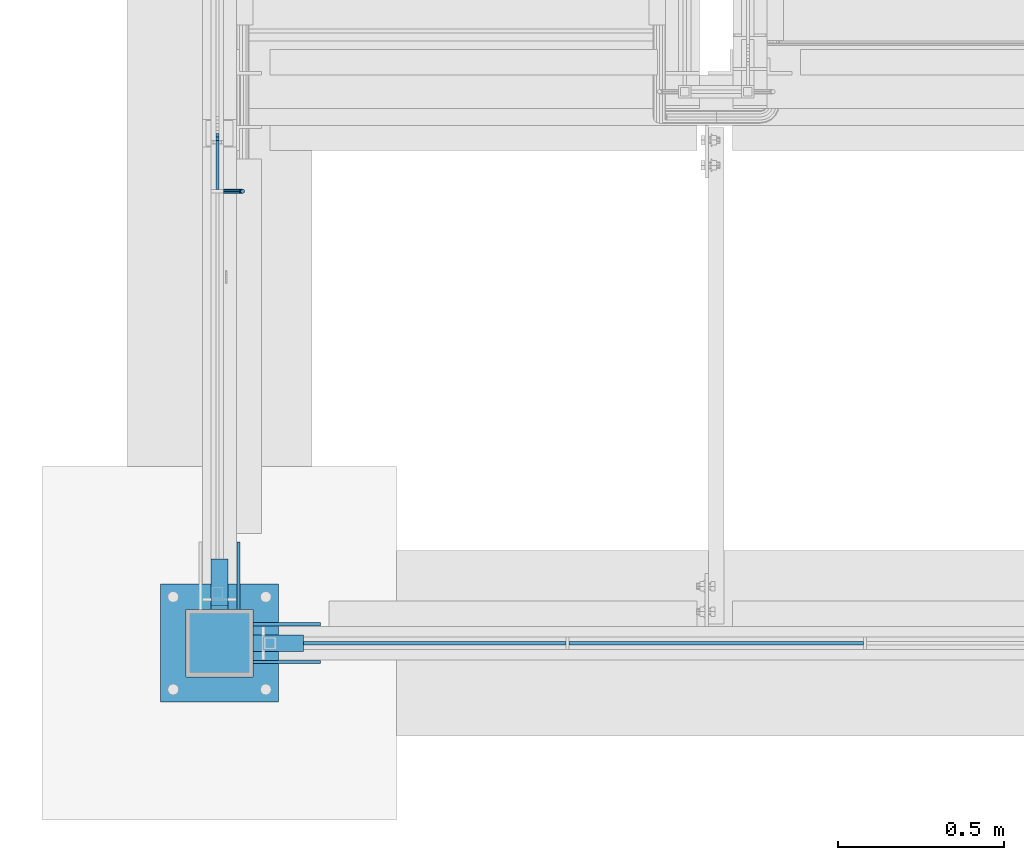
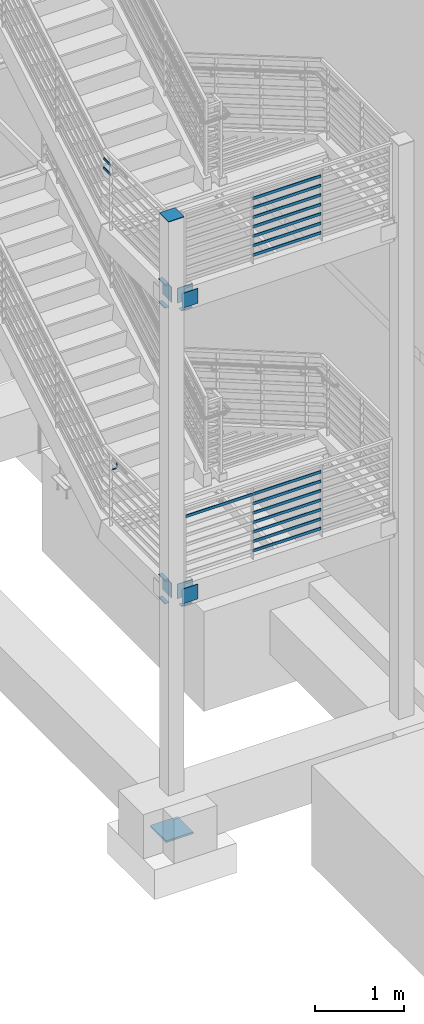
# One storey, part 831 of 1179: 32 beams, 7 elements without a shape of their own.
"""IFC2X3 building model written with IfcOpenShell, lengths in millimetres."""

from ifc_helpers import new_model, si_unit, frame, origin_with_axes, place, context, subcontext, project, spatial, faceted_brep, material, type_object, element, aggregate, save


model = new_model("IFC2X3")

# Units and contexts
model_context = context("Model", 3, precision=1e-05, world=origin_with_axes())
body_context = subcontext(model_context, "Body", "Model", "MODEL_VIEW")
ifc_project = project(units=[si_unit("LENGTHUNIT", "METRE", prefix="MILLI"), si_unit("AREAUNIT", "SQUARE_METRE"), si_unit("VOLUMEUNIT", "CUBIC_METRE"), si_unit("MASSUNIT", "GRAM", prefix="KILO"), si_unit("TIMEUNIT", "SECOND"), si_unit("PLANEANGLEUNIT", "RADIAN"), si_unit("SOLIDANGLEUNIT", "STERADIAN"), si_unit("THERMODYNAMICTEMPERATUREUNIT", "DEGREE_CELSIUS"), si_unit("LUMINOUSINTENSITYUNIT", "LUMEN")], contexts=[model_context])

# Site, building, storey
site_placement = place(None, origin_with_axes())
site = spatial("IfcSite", under=ifc_project, at=site_placement, CompositionType="ELEMENT")
building_placement = place(site_placement, origin_with_axes())
building = spatial("IfcBuilding", under=site, at=building_placement, Name="Undefined", CompositionType="ELEMENT")
storey_placement = place(building_placement, origin_with_axes())
storey = spatial("IfcBuildingStorey", under=building, at=storey_placement, Name="Undefined", CompositionType="ELEMENT", Elevation=0.0)

# Assembly, beam
assembly_1_placement = place(storey_placement, origin_with_axes())
assembly_1 = element("IfcElementAssembly", 1, at=assembly_1_placement, inside=storey, Name="COLUMN", AssemblyPlace="NOTDEFINED", PredefinedType="RIGID_FRAME")
ifc_material_1 = material(Name="STEEL/A572-GR.50")
beam_type_1 = type_object("IfcBeamType", PredefinedType="NOTDEFINED")
beam_1_placement = place(assembly_1_placement, frame((-3251.2, 30327.6, 1857.375), z_axis=(1.0, 0.0, 0.0), x_axis=(0.0, -1.0, 0.0)))
beam_1 = element("IfcBeam", 2, at=beam_1_placement, type_object=beam_type_1, material=ifc_material_1, Name="PLATE", context=body_context, shape_type="Brep", body=[
    faceted_brep([(152.400000000001, -6.35000000000036, 25.4), (152.400000000001, -6.35000000000036, -25.4), (139.700000000004, 6.35000000000036, -25.4), (139.700000000004, 6.35000000000036, 25.4), (0.0, -6.35000000000036, -25.4000000000015), (0.0, -6.35000000000036, 25.4000000000015), (0.0, 6.35000000000036, 25.4000000000015), (0.0, 6.35000000000036, -25.4000000000015)], [[[0, 1, 2, 3]], [[4, 5, 6, 7]], [[6, 5, 0, 3]], [[7, 6, 3, 2]], [[4, 7, 2, 1]], [[5, 4, 1, 0]]]),
])

assembly_2_placement = place(storey_placement, origin_with_axes())
assembly_2 = element("IfcElementAssembly", 3, at=assembly_2_placement, inside=storey, Name="PLATE", AssemblyPlace="NOTDEFINED", PredefinedType="RIGID_FRAME")
beam_2_placement = place(assembly_2_placement, frame((-3251.2, 30327.6, 2174.875), z_axis=(1.0, 0.0, 0.0), x_axis=(0.0, -1.0, 0.0)))
beam_2 = element("IfcBeam", 4, at=beam_2_placement, type_object=beam_type_1, material=ifc_material_1, Name="PLATE", context=body_context, shape_type="Brep", body=[
    faceted_brep([(152.399999999998, 6.35000000000036, 25.4000000000015), (139.699999999998, -6.35000000000036, 25.4000000000015), (139.699999999998, -6.35000000000036, -25.4000000000015), (152.399999999998, 6.35000000000036, -25.4000000000015), (0.0, -6.35000000000036, -25.4000000000015), (0.0, -6.35000000000036, 25.4000000000015), (0.0, 6.35000000000036, 25.4000000000015), (0.0, 6.35000000000036, -25.4000000000015)], [[[0, 1, 2, 3]], [[4, 5, 6, 7]], [[7, 6, 0, 3]], [[4, 7, 3, 2]], [[5, 4, 2, 1]], [[6, 5, 1, 0]]]),
])
aggregate(assembly_2, [beam_2])

# Beam
beam_3_placement = place(assembly_1_placement, frame((-3251.2, 30327.6, 5930.9), z_axis=(1.0, 0.0, 0.0), x_axis=(0.0, -1.0, 0.0)))
beam_3 = element("IfcBeam", 5, at=beam_3_placement, type_object=beam_type_1, material=ifc_material_1, Name="PLATE", context=body_context, shape_type="Brep", body=[
    faceted_brep([(152.400000000001, -6.35000000000036, 25.4), (152.400000000001, -6.35000000000036, -25.4), (139.700000000004, 6.35000000000036, -25.4), (139.700000000004, 6.35000000000036, 25.4), (0.0, -6.35000000000036, -25.4000000000015), (0.0, -6.35000000000036, 25.4000000000015), (0.0, 6.35000000000036, 25.4000000000015), (0.0, 6.35000000000036, -25.4000000000015)], [[[0, 1, 2, 3]], [[4, 5, 6, 7]], [[6, 5, 0, 3]], [[7, 6, 3, 2]], [[4, 7, 2, 1]], [[5, 4, 1, 0]]]),
])

# Assembly, beam
assembly_3_placement = place(storey_placement, origin_with_axes())
assembly_3 = element("IfcElementAssembly", 6, at=assembly_3_placement, inside=storey, Name="PLATE", AssemblyPlace="NOTDEFINED", PredefinedType="RIGID_FRAME")
beam_4_placement = place(assembly_3_placement, frame((-3251.2, 30327.6, 6248.4), z_axis=(1.0, 0.0, 0.0), x_axis=(0.0, -1.0, 0.0)))
beam_4 = element("IfcBeam", 7, at=beam_4_placement, type_object=beam_type_1, material=ifc_material_1, Name="PLATE", context=body_context, shape_type="Brep", body=[
    faceted_brep([(152.399999999998, 6.35000000000036, 25.4000000000015), (139.699999999998, -6.35000000000036, 25.4000000000015), (139.699999999998, -6.35000000000036, -25.4000000000015), (152.399999999998, 6.35000000000036, -25.4000000000015), (0.0, -6.35000000000036, -25.4000000000015), (0.0, -6.35000000000036, 25.4000000000015), (0.0, 6.35000000000036, 25.4000000000015), (0.0, 6.35000000000036, -25.4000000000015)], [[[0, 1, 2, 3]], [[4, 5, 6, 7]], [[7, 6, 0, 3]], [[4, 7, 3, 2]], [[5, 4, 2, 1]], [[6, 5, 1, 0]]]),
])
aggregate(assembly_3, [beam_4])

# Beam
beam_5_placement = place(assembly_1_placement, frame((-2997.2, 30073.6, 1857.375), z_axis=(0.0, 1.0, 0.0), x_axis=(-1.0, 0.0, 0.0)))
beam_5 = element("IfcBeam", 8, at=beam_5_placement, type_object=beam_type_1, material=ifc_material_1, Name="PLATE", context=body_context, shape_type="Brep", body=[
    faceted_brep([(152.399999999998, 6.35000000000036, 25.4000000000015), (139.699999999998, -6.35000000000036, 25.4000000000015), (139.699999999998, -6.35000000000036, -25.4000000000015), (152.399999999998, 6.35000000000036, -25.4000000000015), (0.0, -6.35000000000036, -25.4000000000015), (0.0, -6.35000000000036, 25.4000000000015), (0.0, 6.35000000000036, 25.4000000000015), (0.0, 6.35000000000036, -25.4000000000015)], [[[0, 1, 2, 3]], [[4, 5, 6, 7]], [[7, 6, 0, 3]], [[4, 7, 3, 2]], [[5, 4, 2, 1]], [[6, 5, 1, 0]]]),
])

beam_6_placement = place(assembly_1_placement, frame((-2997.2, 30073.6, 5930.9), z_axis=(0.0, 1.0, 0.0), x_axis=(-1.0, 0.0, 0.0)))
beam_6 = element("IfcBeam", 9, at=beam_6_placement, type_object=beam_type_1, material=ifc_material_1, Name="PLATE", context=body_context, shape_type="Brep", body=[
    faceted_brep([(152.399999999998, 6.35000000000036, 25.4000000000015), (139.699999999998, -6.35000000000036, 25.4000000000015), (139.699999999998, -6.35000000000036, -25.4000000000015), (152.399999999998, 6.35000000000036, -25.4000000000015), (0.0, -6.35000000000036, -25.4000000000015), (0.0, -6.35000000000036, 25.4000000000015), (0.0, 6.35000000000036, 25.4000000000015), (0.0, 6.35000000000036, -25.4000000000015)], [[[0, 1, 2, 3]], [[4, 5, 6, 7]], [[7, 6, 0, 3]], [[4, 7, 3, 2]], [[5, 4, 2, 1]], [[6, 5, 1, 0]]]),
])

# Assembly, beam
assembly_4_placement = place(storey_placement, origin_with_axes())
assembly_4 = element("IfcElementAssembly", 10, at=assembly_4_placement, inside=storey, Name="GUARDRAIL", AssemblyPlace="NOTDEFINED", PredefinedType="RIGID_FRAME")
ifc_material_2 = material(Name="STEEL/A36")
beam_type_2 = type_object("IfcBeamType", PredefinedType="NOTDEFINED")
beam_7_placement = place(assembly_4_placement, frame((-3238.5000060417, 31436.7333332685, 2936.87500000931), z_axis=(0.0, 0.0, 1.0), x_axis=(1.0, 0.0, 0.0)))
beam_7 = element("IfcBeam", 11, at=beam_7_placement, type_object=beam_type_2, material=ifc_material_2, Name="BRACKET", context=body_context, shape_type="Brep", body=[
    faceted_brep([(0.0, -4.49012806053361, 4.49012806053452), (0.0, 0.0, 6.34999999999991), (0.0, 4.49012806053361, 4.49012806053452), (0.0, 6.34999999999854, 0.0), (0.0, 4.49012806053361, -4.49012806053452), (0.0, 0.0, -6.34999999999991), (0.0, -4.49012806053361, -4.49012806053452), (0.0, -6.34999999999854, 0.0), (44.4500031699827, 0.0, -6.34999999999991), (44.4500031699827, -4.49012806053361, -4.49012806053452), (44.4500031699827, -6.34999999999854, 2.19733919948339e-09), (44.4500031699827, -4.49012806053361, 4.49012806053452), (44.4500031699827, 0.0, 6.34999999999991), (44.4500031699827, 4.49012806053361, 4.49012806053452), (44.4500031699827, 6.34999999999854, 0.0), (44.4500031699827, 4.49012806053361, -4.49012806053452), (53.0450671075391, 4.4901280570557, -2.18708762112465), (53.97500307462, -4.32919478043914e-09, -3.79778396764459), (53.0450671022344, -4.49012806401151, -2.1870876194389), (50.8000030708674, -6.35000000142099, 1.70147734757802), (48.5549390416977, -4.4901280599006, 5.59004231389645), (47.6250030746168, 1.48793333210051e-09, 7.20073866041594), (48.5549390470023, 4.49012806117025, 5.5900423122107), (50.8000030783693, 6.34999999857973, 1.70147734519378), (55.4485256393576, 6.34999999469437, 6.34999990618098), (59.337090604122, 4.49012805180246, 4.10493587545716), (51.5599606707875, 4.49012805866005, 8.59506393599531), (49.9492643188311, -4.54747350886464e-10, 9.52499990463002), (51.5599606615996, -4.4901280624108, 8.59506393379797), (55.4485256263639, -6.35000000530636, 6.34999990307369), (59.337090594938, -4.49012806926839, 4.10493587326664), (60.9477869468905, -1.0153598850593e-08, 3.17499990462466), (61.6401310450869, 4.49012804462109, 12.6999998130159), (63.5000029792477, -1.81098585017025e-08, 12.6999998092651), (57.1500029867496, 6.3499999893902, 12.6999998145698), (52.6598749240178, 4.49012805522943, 12.6999998130159), (50.8000029792477, -3.10683390125632e-09, 12.6999998092651), (52.6598749134085, -4.49012806583778, 12.6999998055144), (57.1500029739432, -6.35000001061053, 12.6999998039605), (61.6401310344776, -4.49012807644976, 12.6999998055144), (63.5000029792478, -6.94672053214163e-08, 76.1999999999989), (61.6401310356729, -4.49012812829824, 76.1999999999989), (57.1500029739432, -6.3500000636559, 76.1999999999989), (52.6598749146037, -4.49012812008004, 76.1999999999989), (50.8000029792478, -5.78438630327582e-08, 76.1999999999989), (52.6598749228227, 4.49012800098717, 76.1999999999989), (57.1500029850595, 6.34999993634483, 76.1999999999989), (61.6401310438919, 4.49012799276898, 76.1999999999989)], [[[0, 1, 2, 3, 4, 5, 6, 7]], [[6, 5, 8, 9]], [[7, 6, 9, 10]], [[0, 7, 10, 11]], [[1, 0, 11, 12]], [[2, 1, 12, 13]], [[3, 2, 13, 14]], [[4, 3, 14, 15]], [[5, 4, 15, 8]], [[8, 15, 16, 17]], [[9, 8, 17, 18]], [[10, 9, 18, 19]], [[11, 10, 19, 20]], [[12, 11, 20, 21]], [[13, 12, 21, 22]], [[14, 13, 22, 23]], [[15, 14, 23, 16]], [[23, 24, 25, 16]], [[22, 26, 24, 23]], [[21, 27, 26, 22]], [[20, 28, 27, 21]], [[19, 29, 28, 20]], [[18, 30, 29, 19]], [[17, 31, 30, 18]], [[16, 25, 31, 17]], [[25, 32, 33, 31]], [[24, 34, 32, 25]], [[26, 35, 34, 24]], [[27, 36, 35, 26]], [[28, 37, 36, 27]], [[29, 38, 37, 28]], [[30, 39, 38, 29]], [[31, 33, 39, 30]], [[39, 33, 40, 41]], [[38, 39, 41, 42]], [[37, 38, 42, 43]], [[36, 37, 43, 44]], [[35, 36, 44, 45]], [[34, 35, 45, 46]], [[32, 34, 46, 47]], [[33, 32, 47, 40]], [[46, 45, 44, 43, 42, 41, 40, 47]]]),
])
aggregate(assembly_4, [beam_7])

# Assembly, beams
assembly_5_placement = place(storey_placement, origin_with_axes())
assembly_5 = element("IfcElementAssembly", 12, at=assembly_5_placement, inside=storey, Name="GUARDRAIL", AssemblyPlace="NOTDEFINED", PredefinedType="RIGID_FRAME")
beam_type_3 = type_object("IfcBeamType", PredefinedType="NOTDEFINED")
beam_8_placement = place(assembly_5_placement, frame((-3257.54999923555, 31616.944156247, 7131.09462608346), z_axis=(0.0, 0.0, 1.0), x_axis=(0.0, -1.0, 0.0)))
beam_8 = element("IfcBeam", 13, at=beam_8_placement, type_object=beam_type_3, material=ifc_material_2, Name="PLATE", context=body_context, shape_type="Brep", body=[
    faceted_brep([(16.5954980612551, 4.76249999999982, -19.0500000000002), (26.8953347134957, 4.76249999999982, 19.0500000000002), (175.448322913624, 4.76249999999982, 19.0500000000002), (175.448322913624, 4.76249999999982, -19.0500000000002), (26.8953347134957, -4.76249999999982, 19.0500000000002), (175.448322913624, -4.76249999999982, 19.0500000000002), (16.5954980612551, -4.76249999999982, -19.0500000000002), (175.448322913624, -4.76249999999982, -19.0500000000002)], [[[0, 1, 2, 3]], [[1, 4, 5, 2]], [[4, 6, 7, 5]], [[6, 0, 3, 7]], [[5, 7, 3, 2]], [[6, 4, 1, 0]]]),
])
beam_9_placement = place(assembly_5_placement, frame((-3257.54999923555, 31616.944156247, 7000.90607249299), z_axis=(0.0, 0.0, 1.0), x_axis=(0.0, -1.0, 0.0)))
beam_9 = element("IfcBeam", 14, at=beam_9_placement, type_object=beam_type_3, material=ifc_material_2, Name="PLATE", context=body_context, shape_type="Brep", body=[
    faceted_brep([(6.3188973583201, 4.76249999999982, -19.0500000000002), (16.6187340105607, 4.76249999999982, 19.0500000000002), (175.448322913624, 4.76249999999982, 19.0500000000002), (175.448322913624, 4.76249999999982, -19.0500000000002), (16.6187340105607, -4.76249999999982, 19.0500000000002), (175.448322913624, -4.76249999999982, 19.0500000000002), (6.3188973583201, -4.76249999999982, -19.0500000000002), (175.448322913624, -4.76249999999982, -19.0500000000002)], [[[0, 1, 2, 3]], [[1, 4, 5, 2]], [[4, 6, 7, 5]], [[6, 0, 3, 7]], [[5, 7, 3, 2]], [[6, 4, 1, 0]]]),
])
aggregate(assembly_5, [beam_8, beam_9])

assembly_6_placement = place(storey_placement, origin_with_axes())
assembly_6 = element("IfcElementAssembly", 15, at=assembly_6_placement, inside=storey, Name="GUARDRAIL", AssemblyPlace="NOTDEFINED", PredefinedType="RIGID_FRAME")
beam_10_placement = place(assembly_6_placement, frame((-2201.33333333333, 30073.6, 6350.05291805541), z_axis=(0.0, 0.0, 1.0), x_axis=(1.0, 0.0, 0.0)))
beam_10 = element("IfcBeam", 16, at=beam_10_placement, type_object=beam_type_3, material=ifc_material_2, Name="PLATE", context=body_context, shape_type="Brep", body=[
    faceted_brep([(4.76250000197615, 4.76249999999999, -19.0500000000002), (4.76250000197615, 4.76249999999999, 19.0500000000002), (892.704166666667, 4.76249999999709, 19.0499999999993), (892.704166666667, 4.76249999999709, -19.0499999999993), (4.76250000197615, -4.76249999999999, 19.0500000000002), (892.704166666667, -4.76249999999709, 19.0499999999993), (4.76250000197615, -4.76249999999999, -19.0500000000002), (892.704166666667, -4.76249999999709, -19.0499999999993)], [[[0, 1, 2, 3]], [[1, 4, 5, 2]], [[4, 6, 7, 5]], [[6, 0, 3, 7]], [[5, 7, 3, 2]], [[6, 4, 1, 0]]]),
])
beam_11_placement = place(assembly_6_placement, frame((-2201.33333333333, 30073.6, 6480.22791850857), z_axis=(0.0, 0.0, 1.0), x_axis=(1.0, 0.0, 0.0)))
beam_11 = element("IfcBeam", 17, at=beam_11_placement, type_object=beam_type_3, material=ifc_material_2, Name="PLATE", context=body_context, shape_type="Brep", body=[
    faceted_brep([(4.76250000197615, 4.76249999999999, -19.0500000000002), (4.76250000197615, 4.76249999999999, 19.0500000000002), (892.704166666667, 4.76249999999709, 19.0499999999993), (892.704166666667, 4.76249999999709, -19.0499999999993), (4.76250000197615, -4.76249999999999, 19.0500000000002), (892.704166666667, -4.76249999999709, 19.0499999999993), (4.76250000197615, -4.76249999999999, -19.0500000000002), (892.704166666667, -4.76249999999709, -19.0499999999993)], [[[0, 1, 2, 3]], [[1, 4, 5, 2]], [[4, 6, 7, 5]], [[6, 0, 3, 7]], [[5, 7, 3, 2]], [[6, 4, 1, 0]]]),
])
beam_12_placement = place(assembly_6_placement, frame((-2201.33333333333, 30073.6, 6610.40291806788), z_axis=(0.0, 0.0, 1.0), x_axis=(1.0, 0.0, 0.0)))
beam_12 = element("IfcBeam", 18, at=beam_12_placement, type_object=beam_type_3, material=ifc_material_2, Name="PLATE", context=body_context, shape_type="Brep", body=[
    faceted_brep([(4.76250000197615, 4.76249999999999, -19.0500000000002), (4.76250000197615, 4.76249999999999, 19.0500000000002), (892.704166666667, 4.76249999999709, 19.0499999999993), (892.704166666667, 4.76249999999709, -19.0499999999993), (4.76250000197615, -4.76249999999999, 19.0500000000002), (892.704166666667, -4.76249999999709, 19.0499999999993), (4.76250000197615, -4.76249999999999, -19.0500000000002), (892.704166666667, -4.76249999999709, -19.0499999999993)], [[[0, 1, 2, 3]], [[1, 4, 5, 2]], [[4, 6, 7, 5]], [[6, 0, 3, 7]], [[5, 7, 3, 2]], [[6, 4, 1, 0]]]),
])
beam_13_placement = place(assembly_6_placement, frame((-2201.33333333333, 30073.6, 6740.57791908102), z_axis=(0.0, 0.0, 1.0), x_axis=(1.0, 0.0, 0.0)))
beam_13 = element("IfcBeam", 19, at=beam_13_placement, type_object=beam_type_3, material=ifc_material_2, Name="PLATE", context=body_context, shape_type="Brep", body=[
    faceted_brep([(4.76250000197615, 4.76249999999999, -19.0500000000002), (4.76250000197615, 4.76249999999999, 19.0500000000002), (892.704166666667, 4.76249999999709, 19.0499999999993), (892.704166666667, 4.76249999999709, -19.0499999999993), (4.76250000197615, -4.76249999999999, 19.0500000000002), (892.704166666667, -4.76249999999709, 19.0499999999993), (4.76250000197615, -4.76249999999999, -19.0500000000002), (892.704166666667, -4.76249999999709, -19.0499999999993)], [[[0, 1, 2, 3]], [[1, 4, 5, 2]], [[4, 6, 7, 5]], [[6, 0, 3, 7]], [[5, 7, 3, 2]], [[6, 4, 1, 0]]]),
])
beam_14_placement = place(assembly_6_placement, frame((-2201.33333333333, 30073.6, 6870.75291907929), z_axis=(0.0, 0.0, 1.0), x_axis=(1.0, 0.0, 0.0)))
beam_14 = element("IfcBeam", 20, at=beam_14_placement, type_object=beam_type_3, material=ifc_material_2, Name="PLATE", context=body_context, shape_type="Brep", body=[
    faceted_brep([(4.76250000197615, 4.76249999999999, -19.0500000000002), (4.76250000197615, 4.76249999999999, 19.0500000000002), (892.704166666667, 4.76249999999709, 19.0499999999993), (892.704166666667, 4.76249999999709, -19.0499999999993), (4.76250000197615, -4.76249999999999, 19.0500000000002), (892.704166666667, -4.76249999999709, 19.0499999999993), (4.76250000197615, -4.76249999999999, -19.0500000000002), (892.704166666667, -4.76249999999709, -19.0499999999993)], [[[0, 1, 2, 3]], [[1, 4, 5, 2]], [[4, 6, 7, 5]], [[6, 0, 3, 7]], [[5, 7, 3, 2]], [[6, 4, 1, 0]]]),
])
beam_15_placement = place(assembly_6_placement, frame((-2201.33333333333, 30073.6, 7000.92791908278), z_axis=(0.0, 0.0, 1.0), x_axis=(1.0, 0.0, 0.0)))
beam_15 = element("IfcBeam", 21, at=beam_15_placement, type_object=beam_type_3, material=ifc_material_2, Name="PLATE", context=body_context, shape_type="Brep", body=[
    faceted_brep([(4.76250000197615, 4.76249999999999, -19.0500000000002), (4.76250000197615, 4.76249999999999, 19.0500000000002), (892.704166666667, 4.76249999999709, 19.0499999999993), (892.704166666667, 4.76249999999709, -19.0499999999993), (4.76250000197615, -4.76249999999999, 19.0500000000002), (892.704166666667, -4.76249999999709, 19.0499999999993), (4.76250000197615, -4.76249999999999, -19.0500000000002), (892.704166666667, -4.76249999999709, -19.0499999999993)], [[[0, 1, 2, 3]], [[1, 4, 5, 2]], [[4, 6, 7, 5]], [[6, 0, 3, 7]], [[5, 7, 3, 2]], [[6, 4, 1, 0]]]),
])
beam_16_placement = place(assembly_6_placement, frame((-2201.33333333333, 30073.6, 7131.10291908278), z_axis=(0.0, 0.0, 1.0), x_axis=(1.0, 0.0, 0.0)))
beam_16 = element("IfcBeam", 22, at=beam_16_placement, type_object=beam_type_3, material=ifc_material_2, Name="PLATE", context=body_context, shape_type="Brep", body=[
    faceted_brep([(4.76250000197615, 4.76249999999999, -19.0500000000002), (4.76250000197615, 4.76249999999999, 19.0500000000002), (892.704166666667, 4.76249999999709, 19.0499999999993), (892.704166666667, 4.76249999999709, -19.0499999999993), (4.76250000197615, -4.76249999999999, 19.0500000000002), (892.704166666667, -4.76249999999709, 19.0499999999993), (4.76250000197615, -4.76249999999999, -19.0500000000002), (892.704166666667, -4.76249999999709, -19.0499999999993)], [[[0, 1, 2, 3]], [[1, 4, 5, 2]], [[4, 6, 7, 5]], [[6, 0, 3, 7]], [[5, 7, 3, 2]], [[6, 4, 1, 0]]]),
])
aggregate(assembly_6, [beam_10, beam_11, beam_12, beam_13, beam_14, beam_15, beam_16])

assembly_7_placement = place(storey_placement, origin_with_axes())
assembly_7 = element("IfcElementAssembly", 23, at=assembly_7_placement, inside=storey, Name="GUARDRAIL", AssemblyPlace="NOTDEFINED", PredefinedType="RIGID_FRAME")
beam_17_placement = place(assembly_7_placement, frame((-2201.33333333333, 30073.6, 2276.52791774519), z_axis=(0.0, 0.0, 1.0), x_axis=(1.0, 0.0, 0.0)))
beam_17 = element("IfcBeam", 24, at=beam_17_placement, type_object=beam_type_3, material=ifc_material_2, Name="PLATE", context=body_context, shape_type="Brep", body=[
    faceted_brep([(4.76250000197615, 4.76249999999999, -19.0500000000002), (4.76250000197615, 4.76249999999999, 19.0500000000002), (892.704166666667, 4.76249999999709, 19.0499999999993), (892.704166666667, 4.76249999999709, -19.0499999999993), (4.76250000197615, -4.76249999999999, 19.0500000000002), (892.704166666667, -4.76249999999709, 19.0499999999993), (4.76250000197615, -4.76249999999999, -19.0500000000002), (892.704166666667, -4.76249999999709, -19.0499999999993)], [[[0, 1, 2, 3]], [[1, 4, 5, 2]], [[4, 6, 7, 5]], [[6, 0, 3, 7]], [[5, 7, 3, 2]], [[6, 4, 1, 0]]]),
])
beam_18_placement = place(assembly_7_placement, frame((-2201.33333333333, 30073.6, 2406.70291819834), z_axis=(0.0, 0.0, 1.0), x_axis=(1.0, 0.0, 0.0)))
beam_18 = element("IfcBeam", 25, at=beam_18_placement, type_object=beam_type_3, material=ifc_material_2, Name="PLATE", context=body_context, shape_type="Brep", body=[
    faceted_brep([(4.76250000197615, 4.76249999999999, -19.0500000000002), (4.76250000197615, 4.76249999999999, 19.0500000000002), (892.704166666667, 4.76249999999709, 19.0499999999993), (892.704166666667, 4.76249999999709, -19.0499999999993), (4.76250000197615, -4.76249999999999, 19.0500000000002), (892.704166666667, -4.76249999999709, 19.0499999999993), (4.76250000197615, -4.76249999999999, -19.0500000000002), (892.704166666667, -4.76249999999709, -19.0499999999993)], [[[0, 1, 2, 3]], [[1, 4, 5, 2]], [[4, 6, 7, 5]], [[6, 0, 3, 7]], [[5, 7, 3, 2]], [[6, 4, 1, 0]]]),
])
beam_19_placement = place(assembly_7_placement, frame((-2201.33333333333, 30073.6, 2536.87791775766), z_axis=(0.0, 0.0, 1.0), x_axis=(1.0, 0.0, 0.0)))
beam_19 = element("IfcBeam", 26, at=beam_19_placement, type_object=beam_type_3, material=ifc_material_2, Name="PLATE", context=body_context, shape_type="Brep", body=[
    faceted_brep([(4.76250000197615, 4.76249999999999, -19.0500000000002), (4.76250000197615, 4.76249999999999, 19.0500000000002), (892.704166666667, 4.76249999999709, 19.0499999999993), (892.704166666667, 4.76249999999709, -19.0499999999993), (4.76250000197615, -4.76249999999999, 19.0500000000002), (892.704166666667, -4.76249999999709, 19.0499999999993), (4.76250000197615, -4.76249999999999, -19.0500000000002), (892.704166666667, -4.76249999999709, -19.0499999999993)], [[[0, 1, 2, 3]], [[1, 4, 5, 2]], [[4, 6, 7, 5]], [[6, 0, 3, 7]], [[5, 7, 3, 2]], [[6, 4, 1, 0]]]),
])
beam_20_placement = place(assembly_7_placement, frame((-2201.33333333333, 30073.6, 2667.0529187708), z_axis=(0.0, 0.0, 1.0), x_axis=(1.0, 0.0, 0.0)))
beam_20 = element("IfcBeam", 27, at=beam_20_placement, type_object=beam_type_3, material=ifc_material_2, Name="PLATE", context=body_context, shape_type="Brep", body=[
    faceted_brep([(4.76250000197615, 4.76249999999999, -19.0500000000002), (4.76250000197615, 4.76249999999999, 19.0500000000002), (892.704166666667, 4.76249999999709, 19.0499999999993), (892.704166666667, 4.76249999999709, -19.0499999999993), (4.76250000197615, -4.76249999999999, 19.0500000000002), (892.704166666667, -4.76249999999709, 19.0499999999993), (4.76250000197615, -4.76249999999999, -19.0500000000002), (892.704166666667, -4.76249999999709, -19.0499999999993)], [[[0, 1, 2, 3]], [[1, 4, 5, 2]], [[4, 6, 7, 5]], [[6, 0, 3, 7]], [[5, 7, 3, 2]], [[6, 4, 1, 0]]]),
])
beam_21_placement = place(assembly_7_placement, frame((-2201.33333333333, 30073.6, 2797.22791876907), z_axis=(0.0, 0.0, 1.0), x_axis=(1.0, 0.0, 0.0)))
beam_21 = element("IfcBeam", 28, at=beam_21_placement, type_object=beam_type_3, material=ifc_material_2, Name="PLATE", context=body_context, shape_type="Brep", body=[
    faceted_brep([(4.76250000197615, 4.76249999999999, -19.0500000000002), (4.76250000197615, 4.76249999999999, 19.0500000000002), (892.704166666667, 4.76249999999709, 19.0499999999993), (892.704166666667, 4.76249999999709, -19.0499999999993), (4.76250000197615, -4.76249999999999, 19.0500000000002), (892.704166666667, -4.76249999999709, 19.0499999999993), (4.76250000197615, -4.76249999999999, -19.0500000000002), (892.704166666667, -4.76249999999709, -19.0499999999993)], [[[0, 1, 2, 3]], [[1, 4, 5, 2]], [[4, 6, 7, 5]], [[6, 0, 3, 7]], [[5, 7, 3, 2]], [[6, 4, 1, 0]]]),
])
beam_22_placement = place(assembly_7_placement, frame((-2201.33333333333, 30073.6, 2927.40291877255), z_axis=(0.0, 0.0, 1.0), x_axis=(1.0, 0.0, 0.0)))
beam_22 = element("IfcBeam", 29, at=beam_22_placement, type_object=beam_type_3, material=ifc_material_2, Name="PLATE", context=body_context, shape_type="Brep", body=[
    faceted_brep([(4.76250000197615, 4.76249999999999, -19.0500000000002), (4.76250000197615, 4.76249999999999, 19.0500000000002), (892.704166666667, 4.76249999999709, 19.0499999999993), (892.704166666667, 4.76249999999709, -19.0499999999993), (4.76250000197615, -4.76249999999999, 19.0500000000002), (892.704166666667, -4.76249999999709, 19.0499999999993), (4.76250000197615, -4.76249999999999, -19.0500000000002), (892.704166666667, -4.76249999999709, -19.0499999999993)], [[[0, 1, 2, 3]], [[1, 4, 5, 2]], [[4, 6, 7, 5]], [[6, 0, 3, 7]], [[5, 7, 3, 2]], [[6, 4, 1, 0]]]),
])
beam_23_placement = place(assembly_7_placement, frame((-2201.33333333333, 30073.6, 3057.57791877255), z_axis=(0.0, 0.0, 1.0), x_axis=(1.0, 0.0, 0.0)))
beam_23 = element("IfcBeam", 30, at=beam_23_placement, type_object=beam_type_3, material=ifc_material_2, Name="PLATE", context=body_context, shape_type="Brep", body=[
    faceted_brep([(4.76250000197615, 4.76249999999999, -19.0500000000002), (4.76250000197615, 4.76249999999999, 19.0500000000002), (892.704166666667, 4.76249999999709, 19.0499999999993), (892.704166666667, 4.76249999999709, -19.0499999999993), (4.76250000197615, -4.76249999999999, 19.0500000000002), (892.704166666667, -4.76249999999709, 19.0499999999993), (4.76250000197615, -4.76249999999999, -19.0500000000002), (892.704166666667, -4.76249999999709, -19.0499999999993)], [[[0, 1, 2, 3]], [[1, 4, 5, 2]], [[4, 6, 7, 5]], [[6, 0, 3, 7]], [[5, 7, 3, 2]], [[6, 4, 1, 0]]]),
])
beam_24_placement = place(assembly_7_placement, frame((-3098.8000000022, 30073.6, 3057.57791887596), z_axis=(0.0, 0.0, 1.0), x_axis=(1.0, 0.0, 0.0)))
beam_24 = element("IfcBeam", 31, at=beam_24_placement, type_object=beam_type_3, material=ifc_material_2, Name="PLATE", context=body_context, shape_type="Brep", body=[
    faceted_brep([(19.0499992371956, 4.76249999999709, -19.0499999999993), (19.0499992371956, 4.76249999999709, 19.0499999999993), (892.704166666667, 4.76249999999709, 19.0499999999993), (892.704166666667, 4.76249999999709, -19.0499999999993), (19.0499992371956, -4.76249999999709, 19.0499999999993), (892.704166666667, -4.76249999999709, 19.0499999999993), (19.0499992371956, -4.76249999999709, -19.0499999999993), (892.704166666667, -4.76249999999709, -19.0499999999993)], [[[0, 1, 2, 3]], [[1, 4, 5, 2]], [[4, 6, 7, 5]], [[6, 0, 3, 7]], [[5, 7, 3, 2]], [[6, 4, 1, 0]]]),
])
aggregate(assembly_7, [beam_17, beam_18, beam_19, beam_20, beam_21, beam_22, beam_23, beam_24])

# Beam
beam_type_4 = type_object("IfcBeamType", PredefinedType="NOTDEFINED")
beam_25_placement = place(assembly_1_placement, frame((-3251.2, 29972.0, 7272.3375), z_axis=(1.0, 0.0, 0.0), x_axis=(0.0, 1.0, 0.0)))
beam_25 = element("IfcBeam", 32, at=beam_25_placement, type_object=beam_type_4, material=ifc_material_2, Name="PLATE", context=body_context, shape_type="Brep", body=[
    faceted_brep([(0.0, 4.76250000000073, -101.6), (0.0, 4.76250000000073, 101.6), (203.199999999997, 4.76250000000073, 101.6), (203.199999999997, 4.76250000000073, -101.6), (0.0, -4.76250000000073, 101.6), (203.199999999997, -4.76250000000073, 101.6), (0.0, -4.76250000000073, -101.6), (203.199999999997, -4.76250000000073, -101.6)], [[[0, 1, 2, 3]], [[1, 4, 5, 2]], [[4, 6, 7, 5]], [[6, 0, 3, 7]], [[5, 7, 3, 2]], [[6, 4, 1, 0]]]),
])

beam_26_placement = place(assembly_1_placement, frame((-3194.05, 30378.4, 2016.125), z_axis=(0.0, 0.0, 1.0), x_axis=(0.0, -1.0, 0.0)))
beam_26 = element("IfcBeam", 33, at=beam_26_placement, type_object=beam_type_4, material=ifc_material_2, Name="PLATE", context=body_context, shape_type="Brep", body=[
    faceted_brep([(0.0, 4.76250000000073, -101.6), (0.0, 4.76250000000073, 101.6), (203.199999999997, 4.76250000000073, 101.6), (203.199999999997, 4.76250000000073, -101.6), (0.0, -4.76250000000073, 101.6), (203.199999999997, -4.76250000000073, 101.6), (0.0, -4.76250000000073, -101.6), (203.199999999997, -4.76250000000073, -101.6)], [[[0, 1, 2, 3]], [[1, 4, 5, 2]], [[4, 6, 7, 5]], [[6, 0, 3, 7]], [[5, 7, 3, 2]], [[6, 4, 1, 0]]]),
])

beam_27_placement = place(assembly_1_placement, frame((-3194.05, 30378.4, 6089.65), z_axis=(0.0, 0.0, 1.0), x_axis=(0.0, -1.0, 0.0)))
beam_27 = element("IfcBeam", 34, at=beam_27_placement, type_object=beam_type_4, material=ifc_material_2, Name="PLATE", context=body_context, shape_type="Brep", body=[
    faceted_brep([(0.0, 4.76250000000073, -101.6), (0.0, 4.76250000000073, 101.6), (203.199999999997, 4.76250000000073, 101.6), (203.199999999997, 4.76250000000073, -101.6), (0.0, -4.76250000000073, 101.6), (203.199999999997, -4.76250000000073, 101.6), (0.0, -4.76250000000073, -101.6), (203.199999999997, -4.76250000000073, -101.6)], [[[0, 1, 2, 3]], [[1, 4, 5, 2]], [[4, 6, 7, 5]], [[6, 0, 3, 7]], [[5, 7, 3, 2]], [[6, 4, 1, 0]]]),
])

beam_28_placement = place(assembly_1_placement, frame((-2946.4, 30130.75, 2016.125), z_axis=(0.0, 0.0, 1.0), x_axis=(-1.0, 0.0, 0.0)))
beam_28 = element("IfcBeam", 35, at=beam_28_placement, type_object=beam_type_4, material=ifc_material_2, Name="PLATE", context=body_context, shape_type="Brep", body=[
    faceted_brep([(0.0, 4.76250000000073, -101.6), (0.0, 4.76250000000073, 101.6), (203.199999999997, 4.76250000000073, 101.6), (203.199999999997, 4.76250000000073, -101.6), (0.0, -4.76250000000073, 101.6), (203.199999999997, -4.76250000000073, 101.6), (0.0, -4.76250000000073, -101.6), (203.199999999997, -4.76250000000073, -101.6)], [[[0, 1, 2, 3]], [[1, 4, 5, 2]], [[4, 6, 7, 5]], [[6, 0, 3, 7]], [[5, 7, 3, 2]], [[6, 4, 1, 0]]]),
])

beam_29_placement = place(assembly_1_placement, frame((-2946.4, 30016.45, 2016.125), z_axis=(0.0, 0.0, 1.0), x_axis=(-1.0, 0.0, 0.0)))
beam_29 = element("IfcBeam", 36, at=beam_29_placement, type_object=beam_type_4, material=ifc_material_2, Name="PLATE", context=body_context, shape_type="Brep", body=[
    faceted_brep([(0.0, 4.76250000000073, -101.6), (0.0, 4.76250000000073, 101.6), (203.199999999997, 4.76250000000073, 101.6), (203.199999999997, 4.76250000000073, -101.6), (0.0, -4.76250000000073, 101.6), (203.199999999997, -4.76250000000073, 101.6), (0.0, -4.76250000000073, -101.6), (203.199999999997, -4.76250000000073, -101.6)], [[[0, 1, 2, 3]], [[1, 4, 5, 2]], [[4, 6, 7, 5]], [[6, 0, 3, 7]], [[5, 7, 3, 2]], [[6, 4, 1, 0]]]),
])

beam_30_placement = place(assembly_1_placement, frame((-2946.4, 30130.75, 6089.65), z_axis=(0.0, 0.0, 1.0), x_axis=(-1.0, 0.0, 0.0)))
beam_30 = element("IfcBeam", 37, at=beam_30_placement, type_object=beam_type_4, material=ifc_material_2, Name="PLATE", context=body_context, shape_type="Brep", body=[
    faceted_brep([(0.0, 4.76250000000073, -101.6), (0.0, 4.76250000000073, 101.6), (203.199999999997, 4.76250000000073, 101.6), (203.199999999997, 4.76250000000073, -101.6), (0.0, -4.76250000000073, 101.6), (203.199999999997, -4.76250000000073, 101.6), (0.0, -4.76250000000073, -101.6), (203.199999999997, -4.76250000000073, -101.6)], [[[0, 1, 2, 3]], [[1, 4, 5, 2]], [[4, 6, 7, 5]], [[6, 0, 3, 7]], [[5, 7, 3, 2]], [[6, 4, 1, 0]]]),
])

beam_31_placement = place(assembly_1_placement, frame((-2946.4, 30016.45, 6089.65), z_axis=(0.0, 0.0, 1.0), x_axis=(-1.0, 0.0, 0.0)))
beam_31 = element("IfcBeam", 38, at=beam_31_placement, type_object=beam_type_4, material=ifc_material_2, Name="PLATE", context=body_context, shape_type="Brep", body=[
    faceted_brep([(0.0, 4.76250000000073, -101.6), (0.0, 4.76250000000073, 101.6), (203.199999999997, 4.76250000000073, 101.6), (203.199999999997, 4.76250000000073, -101.6), (0.0, -4.76250000000073, 101.6), (203.199999999997, -4.76250000000073, 101.6), (0.0, -4.76250000000073, -101.6), (203.199999999997, -4.76250000000073, -101.6)], [[[0, 1, 2, 3]], [[1, 4, 5, 2]], [[4, 6, 7, 5]], [[6, 0, 3, 7]], [[5, 7, 3, 2]], [[6, 4, 1, 0]]]),
])

beam_type_5 = type_object("IfcBeamType", PredefinedType="NOTDEFINED")
beam_32_placement = place(assembly_1_placement, frame((-3251.2, 29895.8000030518, -1193.8), z_axis=(-1.0, 0.0, 0.0), x_axis=(0.0, 1.0, 0.0)))
beam_32 = element("IfcBeam", 39, at=beam_32_placement, type_object=beam_type_5, material=ifc_material_1, context=body_context, shape_type="Brep", body=[
    faceted_brep([(0.0, 12.7, -177.8), (9.50323374127038e-06, 12.7000000000007, 177.80000656152), (355.599999999999, 12.7, 177.8), (355.599999999999, 12.7, -177.8), (9.50323374127038e-06, -12.7000000000007, 177.80000656152), (355.599999999999, -12.7, 177.8), (0.0, -12.7, -177.8), (355.599999999999, -12.7, -177.8)], [[[0, 1, 2, 3]], [[1, 4, 5, 2]], [[4, 6, 7, 5]], [[6, 0, 3, 7]], [[5, 7, 3, 2]], [[6, 4, 1, 0]]]),
])

aggregate(assembly_1, [beam_25, beam_26, beam_27, beam_1, beam_3, beam_28, beam_29, beam_5, beam_30, beam_31, beam_6, beam_32])

save(model, "model.ifc")
